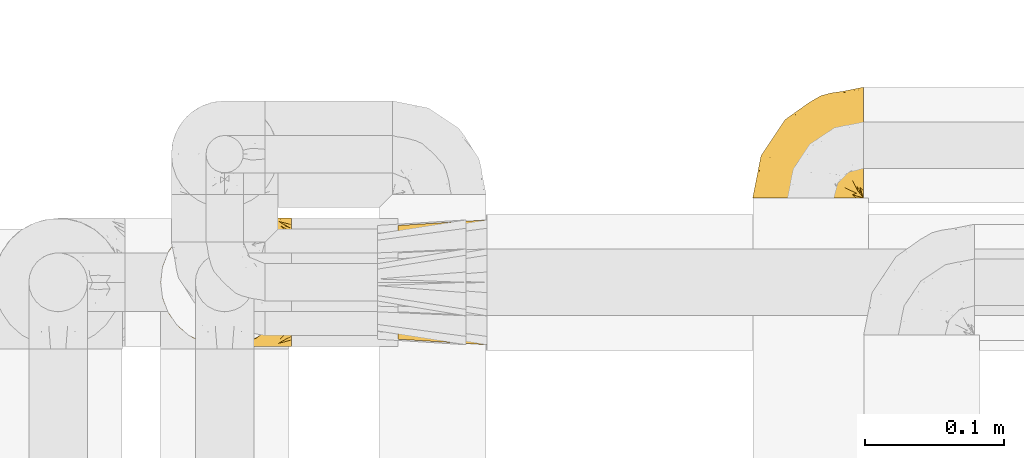
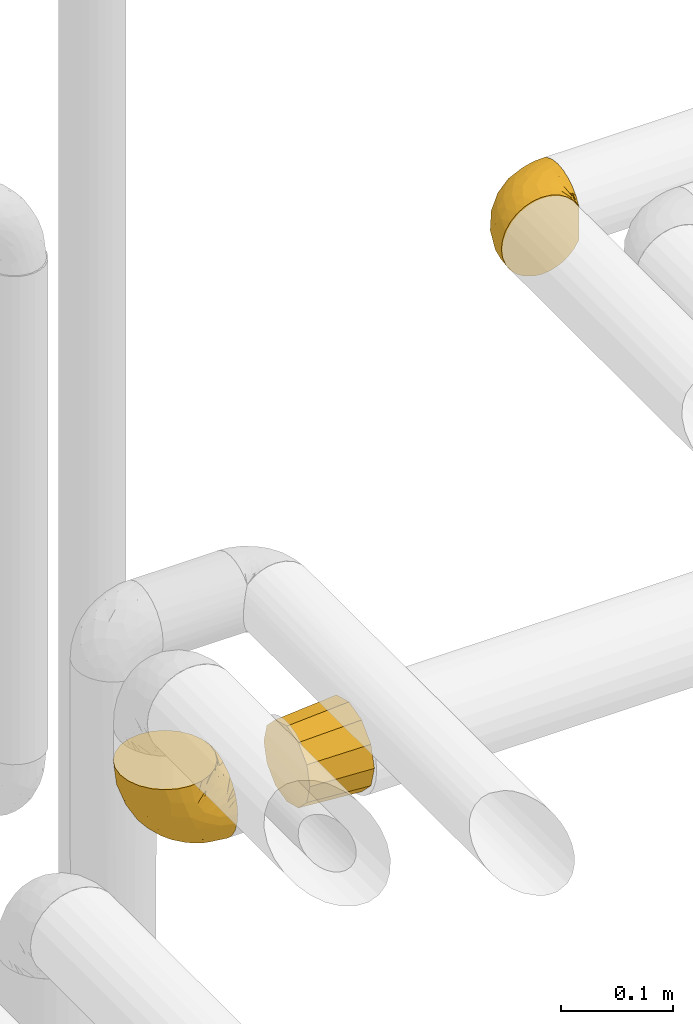
# One storey, part 430 of 827: 3 coverings.
"""IFC2X3 building model written with IfcOpenShell, lengths in millimetres."""

from ifc_helpers import new_model, entity, si_unit, converted_unit, derived_unit, direction, frame, origin, place, context, subcontext, project, spatial, faceted_brep, element, save


model = new_model("IFC2X3")

# Units and contexts
model_context = context("Model", 3, precision=0.01, world=origin(), true_north=direction((6.12303176911189e-17, 1.0)))
body_context = subcontext(model_context, "Body", "Model", "MODEL_VIEW")
ifc_project = project(units=[si_unit("LENGTHUNIT", "METRE", prefix="MILLI"), si_unit("AREAUNIT", "SQUARE_METRE"), si_unit("VOLUMEUNIT", "CUBIC_METRE"), converted_unit("PLANEANGLEUNIT", "DEGREE", entity("IfcRatioMeasure", 0.0174532925199433), si_unit("PLANEANGLEUNIT", "RADIAN"), dimensions=[0, 0, 0, 0, 0, 0, 0]), si_unit("MASSUNIT", "GRAM", prefix="KILO"), derived_unit("MASSDENSITYUNIT", [(si_unit("MASSUNIT", "GRAM", prefix="KILO"), 1), (si_unit("LENGTHUNIT", "METRE"), -3)]), derived_unit("MOMENTOFINERTIAUNIT", [(si_unit("LENGTHUNIT", "METRE"), 4)]), si_unit("TIMEUNIT", "SECOND"), si_unit("FREQUENCYUNIT", "HERTZ"), si_unit("THERMODYNAMICTEMPERATUREUNIT", "DEGREE_CELSIUS"), derived_unit("THERMALTRANSMITTANCEUNIT", [(si_unit("MASSUNIT", "GRAM", prefix="KILO"), 1), (si_unit("THERMODYNAMICTEMPERATUREUNIT", "KELVIN"), -1), (si_unit("TIMEUNIT", "SECOND"), -3)]), derived_unit("VOLUMETRICFLOWRATEUNIT", [(si_unit("LENGTHUNIT", "METRE"), 3), (si_unit("TIMEUNIT", "SECOND"), -1)]), derived_unit("MASSFLOWRATEUNIT", [(si_unit("MASSUNIT", "GRAM", prefix="KILO"), 1), (si_unit("TIMEUNIT", "SECOND"), -1)]), derived_unit("ROTATIONALFREQUENCYUNIT", [(si_unit("TIMEUNIT", "SECOND"), -1)]), si_unit("ELECTRICCURRENTUNIT", "AMPERE"), si_unit("ELECTRICVOLTAGEUNIT", "VOLT"), si_unit("POWERUNIT", "WATT"), si_unit("FORCEUNIT", "NEWTON", prefix="KILO"), si_unit("ILLUMINANCEUNIT", "LUX"), si_unit("LUMINOUSFLUXUNIT", "LUMEN"), si_unit("LUMINOUSINTENSITYUNIT", "CANDELA"), derived_unit("USERDEFINED", [(si_unit("MASSUNIT", "GRAM", prefix="KILO"), -1), (si_unit("LENGTHUNIT", "METRE"), -2), (si_unit("TIMEUNIT", "SECOND"), 3), (si_unit("LUMINOUSFLUXUNIT", "LUMEN"), 1)]), derived_unit("LINEARVELOCITYUNIT", [(si_unit("LENGTHUNIT", "METRE"), 1), (si_unit("TIMEUNIT", "SECOND"), -1)]), si_unit("PRESSUREUNIT", "PASCAL"), derived_unit("USERDEFINED", [(si_unit("LENGTHUNIT", "METRE"), -2), (si_unit("MASSUNIT", "GRAM", prefix="KILO"), 1), (si_unit("TIMEUNIT", "SECOND"), -2)]), derived_unit("LINEARFORCEUNIT", [(si_unit("MASSUNIT", "GRAM", prefix="KILO"), 1), (si_unit("LENGTHUNIT", "METRE"), 1), (si_unit("TIMEUNIT", "SECOND"), -2), (si_unit("LENGTHUNIT", "METRE"), -1)]), derived_unit("PLANARFORCEUNIT", [(si_unit("MASSUNIT", "GRAM", prefix="KILO"), 1), (si_unit("LENGTHUNIT", "METRE"), 1), (si_unit("TIMEUNIT", "SECOND"), -2), (si_unit("LENGTHUNIT", "METRE"), -2)])], contexts=[model_context])

# Site, building, storey
site_placement = place(None, origin())
site = spatial("IfcSite", under=ifc_project, at=site_placement, CompositionType="ELEMENT")
building_placement = place(site_placement, origin())
building = spatial("IfcBuilding", under=site, at=building_placement, CompositionType="ELEMENT")
storey_placement = place(building_placement, frame((0.0, 0.0, 28200.0)))
storey = spatial("IfcBuildingStorey", under=building, at=storey_placement, Name="08", CompositionType="ELEMENT", Elevation=28200.0)

# Coverings
covering_1_placement = place(storey_placement, frame((54141.99, 17452.2, 2519.7)))
element("IfcCovering", 1, at=covering_1_placement, inside=storey, Name=":ADSK_", ObjectType=":ADSK_", PredefinedType="INSULATION", context=body_context, shape_type="Brep", body=[
    faceted_brep([(95.8, 11.68, 18.98), (95.8, 19.0, 11.67), (95.8, 27.76, 6.17), (95.8, 37.52, 2.75), (95.8, 47.8, 1.6), (95.8, 58.08, 2.75), (95.8, 67.85, 6.17), (95.8, 76.61, 11.68), (95.8, 83.92, 19.0), (95.8, 89.42, 27.76), (95.8, 92.84, 37.52), (95.8, 94.0, 47.8), (95.8, 93.53, 51.94), (95.8, 93.18, 55.01), (95.8, 92.84, 58.08), (95.8, 91.13, 62.96), (95.8, 89.42, 67.85), (95.8, 86.66, 72.23), (95.8, 83.91, 76.61), (95.8, 80.25, 80.26), (95.8, 76.59, 83.92), (95.8, 67.83, 89.42), (95.8, 62.95, 91.13), (95.8, 58.07, 92.84), (95.8, 47.8, 94.0), (95.8, 37.51, 92.84), (95.8, 32.63, 91.13), (95.8, 27.74, 89.42), (95.8, 18.98, 83.91), (95.8, 15.33, 80.25), (95.8, 11.67, 76.59), (95.8, 8.92, 72.21), (95.8, 6.17, 67.83), (95.8, 4.46, 62.95), (95.8, 2.75, 58.07), (95.8, 2.41, 55.0), (95.8, 2.06, 51.94), (95.8, 1.6, 47.8), (95.8, 2.75, 37.51), (95.8, 6.17, 27.74), (94.0, 47.8, 95.8), (92.42, 59.75, 95.8), (87.81, 70.9, 95.8), (84.13, 75.68, 95.8), (80.46, 80.46, 95.8), (75.68, 84.13, 95.8), (70.9, 87.81, 95.8), (65.32, 90.11, 95.8), (59.75, 92.42, 95.8), (56.14, 92.9, 95.8), (54.06, 93.17, 95.8), (51.97, 93.45, 95.8), (47.8, 94.0, 95.8), (35.84, 92.42, 95.8), (24.7, 87.81, 95.8), (15.13, 80.46, 95.8), (7.78, 70.9, 95.8), (3.17, 59.75, 95.8), (1.6, 47.8, 95.8), (3.17, 35.84, 95.8), (7.78, 24.7, 95.8), (15.13, 15.13, 95.8), (24.7, 7.78, 95.8), (35.84, 3.17, 95.8), (47.8, 1.6, 95.8), (51.97, 2.14, 95.8), (56.14, 2.69, 95.8), (59.75, 3.17, 95.8), (65.32, 5.48, 95.8), (70.9, 7.78, 95.8), (75.68, 11.46, 95.8), (80.46, 15.13, 95.8), (84.13, 19.91, 95.8), (87.81, 24.7, 95.8), (92.42, 35.84, 95.8), (15.84, 23.61, 60.58), (6.99, 31.99, 74.11), (14.39, 35.87, 51.59), (6.21, 47.8, 66.69), (4.26, 40.43, 76.19), (3.39, 47.8, 84.43), (31.2, 31.83, 31.2), (26.47, 23.37, 42.88), (11.44, 21.41, 79.41), (47.66, 3.07, 60.7), (61.85, 1.6, 61.85), (59.25, 1.6, 65.75), (56.65, 1.6, 69.64), (54.05, 1.6, 73.53), (51.45, 1.6, 77.43), (19.8, 13.45, 74.59), (26.22, 15.25, 54.72), (31.58, 8.07, 64.18), (38.36, 16.0, 37.94), (51.54, 17.34, 25.89), (51.6, 10.58, 34.73), (55.97, 5.34, 42.89), (62.88, 2.39, 49.83), (41.35, 8.36, 48.58), (82.24, 10.04, 22.41), (40.88, 2.59, 78.69), (29.0, 6.28, 81.64), (74.06, 34.28, 6.22), (54.53, 38.73, 12.11), (57.98, 27.25, 14.81), (43.81, 29.88, 21.61), (38.22, 38.6, 22.41), (38.33, 23.44, 30.12), (74.76, 25.25, 10.01), (76.85, 17.23, 15.36), (84.43, 47.8, 3.39), (40.43, 47.8, 19.59), (30.01, 47.8, 30.01), (78.67, 2.53, 41.19), (92.06, 1.6, 48.54), (88.32, 1.6, 49.28), (85.6, 1.6, 49.82), (82.88, 1.6, 50.37), (80.15, 1.6, 50.91), (77.43, 1.6, 51.45), (76.36, 5.71, 31.61), (50.91, 1.6, 80.15), (50.37, 1.6, 82.88), (49.82, 1.6, 85.6), (49.28, 1.6, 88.32), (48.91, 1.6, 90.19), (48.54, 1.6, 92.06), (66.69, 47.8, 6.21), (73.53, 1.6, 54.05), (69.64, 1.6, 56.65), (65.75, 1.6, 59.25), (66.13, 11.89, 24.66), (19.59, 47.8, 40.43), (24.64, 39.69, 35.17), (53.56, 47.8, 12.9), (12.9, 47.8, 53.56), (82.81, 13.84, 85.34), (81.22, 9.16, 78.44), (86.57, 15.79, 84.37), (92.75, 25.75, 89.05), (89.68, 16.09, 82.76), (72.26, 7.51, 86.31), (64.73, 3.99, 83.73), (62.45, 2.66, 77.31), (60.63, 3.16, 87.78), (56.91, 2.35, 87.91), (58.14, 2.23, 81.29), (93.7, 38.35, 93.97), (83.4, 6.18, 70.76), (75.54, 2.7, 63.67), (79.46, 2.93, 62.62), (82.28, 16.01, 90.64), (76.25, 9.08, 84.08), (90.18, 11.68, 77.45), (84.69, 9.3, 76.28), (86.94, 21.65, 91.35), (65.12, 4.65, 88.72), (71.71, 3.65, 71.28), (75.21, 3.61, 68.09), (78.6, 12.8, 91.07), (87.27, 2.43, 57.47), (87.92, 6.83, 70.34), (86.1, 3.7, 62.99), (94.52, 47.8, 94.52), (66.23, 3.37, 76.47), (91.08, 7.03, 69.96), (71.77, 7.87, 89.86), (76.21, 7.26, 78.94), (68.59, 3.41, 73.51), (89.94, 23.81, 89.62), (76.25, 86.5, 84.09), (72.26, 88.08, 86.3), (78.6, 82.79, 91.06), (49.28, 94.0, 88.32), (48.54, 94.0, 92.06), (50.37, 94.0, 82.88), (49.82, 94.0, 85.6), (93.7, 57.24, 93.97), (89.95, 71.76, 89.63), (82.88, 94.0, 50.37), (85.6, 94.0, 49.82), (92.06, 94.0, 48.54), (88.32, 94.0, 49.28), (89.68, 79.49, 82.77), (87.92, 88.75, 70.36), (62.45, 92.93, 77.31), (66.24, 92.22, 76.47), (56.65, 94.0, 69.64), (59.25, 94.0, 65.75), (60.63, 92.43, 87.78), (56.91, 93.24, 87.91), (92.76, 69.82, 89.06), (82.28, 79.57, 90.65), (82.81, 81.74, 85.35), (54.05, 94.0, 73.53), (51.45, 94.0, 77.43), (58.14, 93.36, 81.29), (90.18, 83.9, 77.46), (84.7, 86.28, 76.29), (87.25, 93.16, 57.47), (75.58, 92.88, 63.71), (75.2, 91.98, 68.11), (83.39, 89.41, 70.77), (71.7, 91.93, 71.31), (81.22, 86.42, 78.46), (90.73, 88.82, 69.52), (79.47, 92.66, 62.64), (86.94, 73.93, 91.35), (65.75, 94.0, 59.25), (86.75, 79.5, 84.6), (86.08, 91.89, 62.98), (77.43, 94.0, 51.45), (73.53, 94.0, 54.05), (69.64, 94.0, 56.65), (64.73, 91.6, 83.73), (50.91, 94.0, 80.15), (65.12, 90.94, 88.72), (61.85, 94.0, 61.85), (68.62, 92.16, 73.56), (76.22, 88.32, 78.96), (74.03, 86.13, 91.36), (80.15, 94.0, 50.91), (49.81, 93.2, 62.87), (4.26, 55.16, 76.19), (19.95, 82.02, 73.57), (30.61, 84.29, 56.07), (25.71, 76.94, 49.77), (22.43, 68.33, 44.73), (15.85, 71.98, 60.58), (60.69, 92.52, 47.64), (40.49, 92.9, 78.32), (14.39, 59.72, 51.59), (6.99, 63.6, 74.11), (29.56, 88.89, 76.04), (11.45, 74.18, 79.41), (57.98, 68.35, 14.82), (74.06, 61.33, 6.22), (54.52, 56.86, 12.12), (43.47, 68.62, 23.51), (31.2, 63.76, 31.2), (33.27, 72.19, 34.96), (64.26, 88.69, 33.86), (74.29, 92.19, 38.94), (80.41, 89.75, 30.23), (24.64, 55.9, 35.17), (73.62, 77.99, 15.85), (78.98, 85.21, 22.59), (53.69, 74.99, 21.56), (42.86, 90.23, 55.94), (41.67, 59.86, 20.67), (79.66, 70.75, 9.19), (58.41, 81.72, 25.79), (47.11, 86.53, 41.16), (38.37, 79.6, 37.95)], [[[0, 1, 2, 3, 4, 5, 6, 7, 8, 9, 10, 11, 12, 13, 14, 15, 16, 17, 18, 19, 20, 21, 22, 23, 24, 25, 26, 27, 28, 29, 30, 31, 32, 33, 34, 35, 36, 37, 38, 39]], [[40, 41, 42, 43, 44, 45, 46, 47, 48, 49, 50, 51, 52, 53, 54, 55, 56, 57, 58, 59, 60, 61, 62, 63, 64, 65, 66, 67, 68, 69, 70, 71, 72, 73, 74]], [[75, 76, 77]], [[78, 79, 80]], [[77, 81, 82]], [[76, 75, 83]], [[84, 85, 86, 87, 88, 89]], [[90, 91, 92]], [[76, 60, 59]], [[93, 94, 95]], [[90, 62, 61]], [[83, 61, 60]], [[96, 97, 84]], [[98, 93, 95]], [[0, 39, 99]], [[100, 84, 89]], [[62, 101, 63]], [[2, 102, 3]], [[92, 84, 100]], [[103, 102, 104]], [[103, 105, 106]], [[93, 107, 94]], [[1, 108, 2]], [[92, 101, 90]], [[108, 1, 109]], [[102, 110, 3]], [[93, 82, 107]], [[102, 108, 104]], [[111, 106, 112]], [[109, 0, 99]], [[113, 37, 114, 115, 116, 117, 118, 119]], [[120, 38, 113]], [[100, 89, 121, 122, 123, 124, 125, 126, 64]], [[127, 102, 103]], [[97, 119, 128, 129, 130, 85]], [[99, 120, 131]], [[132, 133, 77]], [[59, 80, 79]], [[1, 0, 109]], [[98, 84, 92]], [[94, 109, 131]], [[120, 39, 38]], [[93, 91, 82]], [[104, 94, 105]], [[97, 113, 119]], [[95, 120, 96]], [[83, 90, 61]], [[91, 93, 98]], [[64, 63, 100]], [[100, 63, 101]], [[77, 76, 79]], [[133, 106, 81]], [[84, 97, 85]], [[113, 96, 120]], [[113, 97, 96]], [[37, 113, 38]], [[110, 102, 127]], [[110, 4, 3]], [[103, 111, 134, 127]], [[90, 75, 91]], [[82, 81, 107]], [[91, 75, 82]], [[77, 82, 75]], [[76, 83, 60]], [[90, 83, 75]], [[105, 107, 81]], [[94, 131, 95]], [[105, 94, 107]], [[109, 94, 104]], [[120, 95, 131]], [[98, 95, 96]], [[84, 98, 96]], [[98, 92, 91]], [[106, 105, 81]], [[103, 104, 105]], [[112, 106, 133]], [[103, 106, 111]], [[112, 133, 132]], [[81, 77, 133]], [[77, 78, 135, 132]], [[120, 99, 39]], [[109, 99, 131]], [[59, 58, 80]], [[59, 79, 76]], [[90, 101, 62]], [[100, 101, 92]], [[2, 108, 102]], [[109, 104, 108]], [[78, 77, 79]], [[136, 137, 138]], [[27, 139, 140]], [[141, 142, 143]], [[144, 145, 121]], [[146, 89, 88]], [[147, 139, 25]], [[148, 149, 150]], [[136, 151, 152]], [[147, 40, 74]], [[24, 147, 25]], [[153, 140, 154]], [[33, 116, 34]], [[73, 151, 155]], [[114, 37, 36, 35, 34, 116, 115]], [[146, 156, 144]], [[157, 85, 130]], [[158, 149, 148]], [[151, 159, 152]], [[117, 33, 160]], [[29, 153, 161]], [[155, 74, 73]], [[162, 128, 119]], [[66, 65, 64, 126, 125, 124, 123, 122, 67]], [[163, 147, 24]], [[27, 140, 28]], [[149, 129, 150]], [[139, 27, 26, 25]], [[68, 144, 69]], [[129, 128, 150]], [[164, 87, 86]], [[130, 129, 149]], [[122, 145, 67]], [[153, 154, 148]], [[162, 119, 160]], [[165, 30, 161]], [[150, 161, 148]], [[128, 162, 150]], [[30, 165, 31]], [[145, 144, 68]], [[89, 146, 144]], [[87, 164, 143]], [[166, 156, 142]], [[88, 87, 143]], [[162, 161, 150]], [[161, 30, 29]], [[161, 153, 148]], [[28, 140, 153]], [[29, 28, 153]], [[140, 137, 154]], [[158, 148, 154]], [[157, 130, 158]], [[154, 137, 158]], [[158, 137, 157]], [[167, 137, 136]], [[168, 85, 157]], [[152, 168, 167]], [[167, 168, 157]], [[164, 152, 141]], [[151, 73, 72]], [[159, 72, 71]], [[88, 142, 146]], [[144, 156, 69]], [[146, 142, 156]], [[70, 166, 71]], [[142, 141, 166]], [[70, 69, 156]], [[141, 159, 71]], [[167, 136, 152]], [[138, 137, 140]], [[155, 136, 169]], [[136, 155, 151]], [[74, 155, 169]], [[152, 159, 141]], [[151, 72, 159]], [[168, 152, 164]], [[137, 167, 157]], [[164, 86, 168]], [[85, 168, 86]], [[116, 33, 117]], [[130, 149, 158]], [[67, 145, 68]], [[121, 89, 144]], [[145, 122, 121]], [[40, 147, 163]], [[169, 147, 74]], [[160, 33, 32]], [[162, 160, 32]], [[160, 119, 118, 117]], [[139, 147, 169]], [[139, 169, 138]], [[162, 32, 31]], [[141, 143, 164]], [[88, 143, 142]], [[71, 166, 141]], [[156, 166, 70]], [[139, 138, 140]], [[169, 136, 138]], [[161, 162, 165]], [[162, 31, 165]], [[170, 171, 172]], [[173, 174, 52, 51, 50, 49, 48, 175, 176]], [[177, 178, 41]], [[179, 15, 180]], [[12, 11, 181, 182, 180, 14, 13]], [[183, 21, 20]], [[19, 18, 184]], [[185, 186, 187]], [[186, 188, 187]], [[43, 172, 44]], [[189, 190, 47]], [[23, 22, 21, 191]], [[170, 192, 193]], [[40, 163, 177]], [[194, 195, 196]], [[24, 23, 177]], [[197, 198, 183]], [[199, 15, 179]], [[47, 46, 189]], [[200, 201, 202]], [[201, 203, 204]], [[205, 206, 184]], [[207, 41, 178]], [[16, 15, 199]], [[14, 180, 15]], [[202, 201, 198]], [[208, 201, 200]], [[163, 24, 177]], [[48, 47, 190]], [[196, 195, 189]], [[197, 184, 202]], [[204, 193, 209]], [[210, 211, 212]], [[206, 212, 213]], [[205, 17, 210]], [[184, 206, 202]], [[210, 212, 206]], [[185, 194, 214]], [[189, 215, 190]], [[216, 45, 214]], [[186, 171, 170]], [[189, 216, 196]], [[197, 20, 19]], [[194, 185, 187]], [[197, 183, 20]], [[184, 197, 19]], [[197, 202, 198]], [[206, 200, 202]], [[204, 183, 198]], [[201, 208, 203]], [[203, 208, 217]], [[204, 198, 201]], [[217, 188, 218]], [[193, 219, 170]], [[171, 186, 185]], [[170, 218, 186]], [[170, 219, 218]], [[42, 207, 192]], [[171, 220, 172]], [[216, 189, 46]], [[214, 194, 196]], [[44, 220, 45]], [[214, 196, 216]], [[216, 46, 45]], [[214, 45, 220]], [[192, 43, 42]], [[204, 203, 219]], [[207, 193, 192]], [[209, 193, 178]], [[41, 207, 42]], [[193, 207, 178]], [[43, 192, 172]], [[170, 172, 192]], [[204, 219, 193]], [[219, 203, 218]], [[217, 218, 203]], [[188, 186, 218]], [[206, 213, 200]], [[208, 200, 213]], [[199, 210, 16]], [[215, 189, 195]], [[215, 175, 190]], [[175, 48, 190]], [[199, 179, 221, 211]], [[210, 199, 211]], [[23, 191, 177]], [[40, 177, 41]], [[178, 177, 191]], [[21, 183, 191]], [[209, 191, 183]], [[205, 18, 17]], [[17, 16, 210]], [[171, 185, 214]], [[172, 220, 44]], [[214, 220, 171]], [[191, 209, 178]], [[204, 209, 183]], [[206, 205, 210]], [[18, 205, 184]], [[222, 195, 194, 187, 188, 217]], [[57, 223, 80]], [[224, 225, 226]], [[226, 227, 228]], [[229, 217, 208, 213, 212, 211]], [[230, 52, 174, 173, 176, 175, 215, 195]], [[231, 232, 228]], [[231, 78, 223]], [[223, 57, 232]], [[224, 233, 225]], [[233, 54, 53]], [[234, 232, 56]], [[56, 55, 234]], [[234, 224, 228]], [[235, 236, 237]], [[224, 55, 54]], [[238, 239, 240]], [[52, 230, 53]], [[241, 242, 243]], [[231, 227, 244]], [[11, 10, 242]], [[236, 6, 5]], [[7, 245, 8]], [[8, 246, 9]], [[238, 247, 235]], [[222, 229, 248]], [[242, 211, 221, 179, 180, 182, 181, 11]], [[233, 53, 230]], [[111, 112, 249]], [[250, 6, 236]], [[246, 251, 241]], [[6, 250, 7]], [[127, 236, 110]], [[248, 229, 252]], [[246, 8, 245]], [[235, 245, 250]], [[236, 5, 110]], [[235, 249, 238]], [[237, 236, 127]], [[243, 9, 246]], [[252, 229, 241]], [[56, 232, 57]], [[222, 230, 195]], [[225, 248, 252]], [[248, 233, 230]], [[54, 233, 224]], [[231, 228, 227]], [[244, 132, 231]], [[248, 225, 233]], [[226, 225, 253]], [[235, 250, 236]], [[245, 7, 250]], [[251, 246, 245]], [[243, 246, 241]], [[247, 245, 235]], [[252, 251, 253]], [[229, 222, 217]], [[230, 222, 248]], [[5, 4, 110]], [[237, 127, 134, 111]], [[238, 249, 239]], [[224, 234, 55]], [[232, 234, 228]], [[242, 241, 229]], [[10, 9, 243]], [[211, 242, 229]], [[10, 243, 242]], [[80, 223, 78]], [[80, 58, 57]], [[231, 223, 232]], [[227, 240, 239]], [[224, 226, 228]], [[240, 226, 253]], [[227, 239, 244]], [[226, 240, 227]], [[251, 247, 253]], [[240, 253, 247]], [[249, 235, 237]], [[237, 111, 249]], [[244, 239, 249]], [[112, 244, 249]], [[135, 78, 231, 132]], [[112, 132, 244]], [[247, 238, 240]], [[245, 247, 251]], [[251, 252, 241]], [[225, 252, 253]]]),
])
covering_2_placement = place(storey_placement, frame((54314.79, 17453.4, 2520.9)))
element("IfcCovering", 2, at=covering_2_placement, inside=storey, Name=":ADSK_", ObjectType=":ADSK_", PredefinedType="INSULATION", context=body_context, shape_type="Brep", body=[
    faceted_brep([(0.0, 74.6, 74.6), (0.0, 82.1, 67.1), (0.0, 84.85, 56.85), (0.0, 87.6, 46.6), (0.0, 84.85, 36.35), (0.0, 82.1, 26.1), (0.0, 74.6, 18.59), (0.0, 67.1, 11.09), (0.0, 56.85, 8.34), (0.0, 46.6, 5.6), (0.0, 36.35, 8.34), (0.0, 26.1, 11.09), (0.0, 18.59, 18.59), (0.0, 11.09, 26.1), (0.0, 8.34, 36.35), (0.0, 5.6, 46.6), (0.0, 8.34, 56.85), (0.0, 11.09, 67.1), (0.0, 18.59, 74.6), (0.0, 26.1, 82.1), (0.0, 36.35, 84.85), (0.0, 46.6, 87.6), (0.0, 56.85, 84.85), (0.0, 67.1, 82.1), (64.0, 33.21, 88.01), (64.0, 24.1, 85.57), (64.0, 15.86, 77.33), (64.0, 7.62, 69.1), (64.0, 5.18, 59.99), (64.0, 1.6, 46.6), (64.0, 5.18, 33.21), (64.0, 7.62, 24.1), (64.0, 15.86, 15.86), (64.0, 24.1, 7.62), (64.0, 33.21, 5.18), (64.0, 46.6, 1.6), (64.0, 59.99, 5.18), (64.0, 69.1, 7.62), (64.0, 77.33, 15.86), (64.0, 85.57, 24.1), (64.0, 88.01, 33.21), (64.0, 91.6, 46.6), (64.0, 88.01, 59.99), (64.0, 85.57, 69.1), (64.0, 77.33, 77.33), (64.0, 69.1, 85.57), (64.0, 59.99, 88.01), (64.0, 46.6, 91.6)], [[[0, 1, 2, 3, 4, 5, 6, 7, 8, 9, 10, 11, 12, 13, 14, 15, 16, 17, 18, 19, 20, 21, 22, 23]], [[24, 25, 26, 27, 28, 29, 30, 31, 32, 33, 34, 35, 36, 37, 38, 39, 40, 41, 42, 43, 44, 45, 46, 47]], [[7, 37, 36, 35, 9, 8]], [[39, 38, 37, 7, 6, 5]], [[4, 3, 41, 40, 39, 5]], [[13, 31, 30, 29, 15, 14]], [[33, 32, 31, 13, 12, 11]], [[10, 9, 35, 34, 33, 11]], [[19, 25, 24, 47, 21, 20]], [[27, 26, 25, 19, 18, 17]], [[16, 15, 29, 28, 27, 17]], [[1, 43, 42, 41, 3, 2]], [[45, 44, 43, 1, 0, 23]], [[22, 21, 47, 46, 45, 23]]]),
])
covering_3_placement = place(storey_placement, frame((54568.74, 17559.22, 2956.64)))
element("IfcCovering", 3, at=covering_3_placement, inside=storey, Name=":ADSK_", ObjectType=":ADSK_", PredefinedType="INSULATION", context=body_context, shape_type="Brep", body=[
    faceted_brep([(25.28, 1.6, 81.15), (17.35, 1.6, 76.16), (10.72, 1.6, 69.53), (5.74, 1.6, 61.6), (2.64, 1.6, 52.75), (1.6, 1.6, 43.45), (2.65, 1.6, 34.13), (5.74, 1.6, 25.28), (10.73, 1.6, 17.35), (17.36, 1.6, 10.72), (25.29, 1.6, 5.74), (34.14, 1.6, 2.64), (43.45, 1.6, 1.6), (52.82, 1.6, 2.66), (61.71, 1.6, 5.79), (69.67, 1.6, 10.83), (76.31, 1.6, 17.53), (81.27, 1.6, 25.53), (81.27, 1.6, 26.45), (81.27, 1.6, 27.37), (81.27, 1.6, 28.17), (81.27, 1.6, 29.49), (81.27, 1.6, 30.81), (81.27, 1.6, 32.13), (81.27, 1.6, 33.45), (81.27, 1.6, 34.78), (81.27, 1.6, 36.1), (81.27, 1.6, 37.42), (81.27, 1.6, 38.74), (81.27, 1.6, 40.06), (81.27, 1.6, 41.38), (81.27, 1.6, 42.7), (81.27, 1.6, 44.02), (81.27, 1.6, 45.34), (81.27, 1.6, 46.66), (81.27, 1.6, 47.58), (81.27, 1.6, 48.5), (81.27, 1.6, 49.41), (81.27, 1.6, 50.33), (81.27, 1.6, 51.25), (81.27, 1.6, 52.17), (81.27, 1.6, 53.09), (81.27, 1.6, 54.01), (81.27, 1.6, 54.93), (81.27, 1.6, 55.85), (81.27, 1.6, 56.76), (81.27, 1.6, 57.68), (81.27, 1.6, 58.6), (81.27, 1.6, 59.52), (81.27, 1.6, 60.44), (81.27, 1.6, 61.36), (76.3, 1.6, 69.37), (69.66, 1.6, 76.07), (61.69, 1.6, 81.11), (52.8, 1.6, 84.24), (43.45, 1.6, 85.3), (34.13, 1.6, 84.24), (81.45, 6.74, 17.52), (81.45, 13.37, 10.83), (81.45, 21.34, 5.79), (81.45, 30.23, 2.66), (81.45, 39.6, 1.6), (81.45, 50.43, 3.02), (81.45, 60.52, 7.2), (81.45, 69.19, 13.85), (81.45, 75.84, 22.52), (81.45, 80.02, 32.61), (81.45, 81.45, 43.45), (81.45, 80.02, 54.28), (81.45, 75.84, 64.37), (81.45, 69.19, 73.04), (81.45, 60.52, 79.69), (81.45, 50.43, 83.87), (81.45, 39.6, 85.3), (81.45, 30.23, 84.23), (81.45, 21.34, 81.1), (81.45, 13.37, 76.06), (81.45, 6.74, 69.37), (81.45, 1.77, 61.36), (81.45, 1.77, 60.44), (81.45, 1.77, 59.12), (81.45, 1.77, 58.0), (81.45, 1.77, 56.88), (81.45, 1.77, 55.76), (81.45, 1.77, 54.64), (81.45, 1.77, 53.52), (81.45, 1.77, 52.4), (81.45, 1.77, 51.28), (81.45, 1.77, 50.16), (81.45, 1.77, 49.04), (81.45, 1.77, 47.92), (81.45, 1.77, 46.8), (81.45, 1.77, 45.68), (81.45, 1.77, 44.56), (81.45, 1.77, 43.45), (81.45, 1.77, 42.12), (81.45, 1.77, 40.8), (81.45, 1.77, 39.48), (81.45, 1.77, 38.16), (81.45, 1.77, 36.84), (81.45, 1.77, 35.52), (81.45, 1.77, 34.2), (81.45, 1.77, 32.88), (81.45, 1.77, 31.96), (81.45, 1.77, 31.05), (81.45, 1.77, 30.13), (81.45, 1.77, 29.21), (81.45, 1.77, 28.29), (81.45, 1.77, 27.37), (81.45, 1.77, 26.45), (81.45, 1.77, 25.53), (81.33, 1.73, 54.08), (81.32, 1.72, 55.16), (81.33, 1.73, 36.18), (81.32, 1.72, 35.13), (81.33, 1.73, 44.01), (81.32, 1.73, 45.08), (81.32, 1.72, 61.36), (81.32, 1.72, 59.98), (81.32, 1.72, 46.18), (81.32, 1.72, 26.74), (81.32, 1.72, 47.36), (81.32, 1.73, 29.67), (81.34, 1.74, 28.72), (81.32, 1.72, 39.77), (81.31, 1.71, 52.96), (81.33, 1.73, 51.84), (81.31, 1.71, 40.8), (81.32, 1.72, 41.87), (81.33, 1.73, 42.94), (81.32, 1.72, 27.77), (81.33, 1.73, 48.4), (81.32, 1.72, 37.21), (81.33, 1.73, 33.54), (81.32, 1.72, 32.49), (81.32, 1.72, 30.69), (81.32, 1.72, 50.69), (81.31, 1.71, 49.6), (81.32, 1.72, 56.32), (81.33, 1.73, 57.44), (81.31, 1.71, 58.88), (81.32, 1.72, 25.53), (81.3, 1.68, 61.36), (81.29, 1.64, 61.36), (81.29, 1.64, 25.53), (81.3, 1.68, 25.53), (81.4, 1.75, 61.36), (81.36, 1.74, 25.53), (81.36, 1.74, 61.36), (81.4, 1.75, 25.53), (81.3, 1.7, 31.59), (81.33, 1.73, 38.71), (74.06, 24.54, 3.97), (45.99, 11.1, 1.6), (58.35, 8.47, 3.97), (67.76, 9.11, 8.09), (66.18, 4.86, 8.09), (76.46, 5.0, 16.43), (77.33, 6.81, 15.73), (71.95, 37.05, 1.6), (72.25, 9.03, 10.79), (78.91, 9.47, 13.99), (76.42, 16.39, 8.08), (73.52, 3.95, 14.0), (76.9, 9.9, 12.83), (65.25, 22.7, 3.18), (62.45, 34.5, 1.6), (74.31, 37.68, 1.6), (59.38, 15.82, 3.28), (48.54, 20.6, 1.6), (67.72, 14.37, 6.28), (55.49, 27.55, 1.6), (79.73, 5.2, 19.06), (73.23, 14.88, 8.08), (45.36, 8.73, 1.6), (15.81, 44.27, 32.11), (6.4, 20.94, 29.62), (7.67, 32.15, 43.45), (68.46, 46.13, 2.45), (59.33, 42.67, 2.5), (48.7, 55.18, 9.73), (53.94, 67.27, 17.97), (65.02, 62.91, 10.24), (60.77, 51.5, 4.78), (72.07, 54.79, 4.78), (26.25, 25.78, 8.01), (22.29, 13.05, 8.01), (16.0, 18.46, 13.85), (46.93, 32.4, 2.42), (14.19, 31.07, 21.17), (58.46, 77.32, 35.73), (61.51, 75.62, 27.43), (4.64, 16.9, 43.45), (68.93, 71.69, 17.97), (29.62, 61.4, 35.71), (24.85, 54.47, 29.47), (38.55, 27.66, 3.41), (31.27, 14.53, 3.94), (9.35, 15.56, 21.17), (37.15, 42.26, 7.92), (47.07, 41.51, 4.25), (26.49, 36.93, 11.75), (23.01, 42.72, 18.31), (19.4, 44.68, 24.94), (48.06, 71.2, 28.78), (42.46, 70.48, 35.82), (50.89, 75.37, 43.45), (35.78, 63.65, 28.38), (24.98, 58.06, 43.45), (16.33, 45.11, 43.45), (66.14, 78.4, 43.45), (30.96, 54.95, 21.21), (41.83, 59.31, 16.48), (33.28, 49.01, 13.85), (37.94, 66.71, 43.45), (67.39, 53.75, 82.11), (58.47, 77.27, 51.41), (32.5, 61.6, 57.45), (15.79, 44.24, 54.78), (15.99, 18.46, 73.03), (9.34, 15.55, 65.7), (56.91, 60.14, 76.65), (63.5, 70.5, 68.92), (44.08, 63.0, 68.01), (26.24, 25.78, 78.88), (22.27, 13.05, 78.88), (31.26, 14.53, 82.94), (23.95, 48.5, 64.44), (63.79, 44.23, 84.49), (62.45, 34.5, 85.3), (71.95, 37.05, 85.3), (45.36, 8.73, 85.3), (67.83, 77.68, 57.84), (70.28, 64.08, 76.65), (42.11, 70.25, 51.19), (6.39, 20.93, 57.26), (43.54, 49.9, 78.14), (58.03, 49.6, 82.35), (14.18, 31.06, 65.7), (56.34, 39.62, 84.61), (48.09, 34.42, 84.36), (48.54, 20.6, 85.3), (55.49, 27.55, 85.3), (21.78, 33.36, 73.03), (38.54, 27.68, 83.48), (45.99, 11.1, 85.3), (72.79, 46.67, 84.54), (33.26, 49.0, 73.03), (35.53, 38.94, 79.54), (53.66, 73.05, 59.46), (43.03, 56.63, 73.5), (49.68, 43.85, 82.57), (74.06, 24.54, 82.92), (59.37, 15.82, 83.62), (58.34, 8.47, 82.92), (67.75, 9.12, 78.81), (78.91, 9.47, 72.9), (76.9, 9.91, 74.06), (78.08, 16.85, 78.81), (73.23, 14.88, 78.81), (79.73, 5.2, 67.83), (77.34, 6.81, 71.15), (73.51, 3.96, 72.91), (76.45, 5.0, 70.47), (66.41, 5.86, 78.81), (67.7, 14.38, 80.62), (72.24, 9.04, 76.11), (65.25, 22.7, 83.71)], [[[0, 1, 2, 3, 4, 5, 6, 7, 8, 9, 10, 11, 12, 13, 14, 15, 16, 17, 18, 19, 20, 21, 22, 23, 24, 25, 26, 27, 28, 29, 30, 31, 32, 33, 34, 35, 36, 37, 38, 39, 40, 41, 42, 43, 44, 45, 46, 47, 48, 49, 50, 51, 52, 53, 54, 55, 56]], [[57, 58, 59, 60, 61, 62, 63, 64, 65, 66, 67, 68, 69, 70, 71, 72, 73, 74, 75, 76, 77, 78, 79, 80, 81, 82, 83, 84, 85, 86, 87, 88, 89, 90, 91, 92, 93, 94, 95, 96, 97, 98, 99, 100, 101, 102, 103, 104, 105, 106, 107, 108, 109, 110]], [[111, 84, 112]], [[113, 26, 114]], [[114, 101, 100]], [[115, 93, 116]], [[79, 117, 118]], [[33, 116, 119]], [[117, 49, 118]], [[19, 18, 120]], [[119, 121, 34]], [[122, 21, 123]], [[97, 96, 124]], [[86, 125, 126]], [[116, 92, 119]], [[127, 96, 128]], [[32, 129, 115]], [[19, 120, 130]], [[121, 90, 131]], [[94, 115, 129]], [[115, 116, 32]], [[118, 49, 48]], [[113, 99, 132]], [[133, 114, 25]], [[24, 134, 133]], [[135, 22, 122]], [[136, 137, 88]], [[84, 83, 112]], [[138, 82, 139]], [[130, 20, 19]], [[118, 48, 140]], [[81, 140, 139]], [[123, 21, 20]], [[141, 120, 18]], [[139, 82, 81]], [[130, 107, 123]], [[49, 117, 142, 143, 50]], [[18, 17, 144, 145, 141]], [[79, 78, 146]], [[109, 141, 147]], [[79, 148, 117]], [[109, 149, 110]], [[102, 133, 134]], [[105, 135, 122]], [[118, 80, 79]], [[80, 118, 140]], [[120, 109, 108]], [[47, 46, 140, 48]], [[81, 80, 140]], [[44, 112, 138]], [[93, 115, 94]], [[46, 139, 140]], [[46, 45, 139]], [[139, 45, 138]], [[138, 112, 83]], [[85, 84, 111]], [[112, 43, 111]], [[83, 82, 138]], [[106, 122, 123]], [[105, 122, 106]], [[21, 122, 22]], [[124, 29, 28]], [[33, 32, 116]], [[128, 129, 31]], [[32, 31, 129]], [[34, 33, 119]], [[116, 93, 92]], [[129, 95, 94]], [[95, 129, 128]], [[41, 40, 125, 42]], [[119, 91, 121]], [[36, 35, 131, 37]], [[137, 131, 89]], [[121, 131, 35]], [[90, 121, 91]], [[119, 92, 91]], [[136, 126, 39]], [[125, 86, 85]], [[42, 125, 111]], [[85, 111, 125]], [[150, 23, 22]], [[130, 108, 107]], [[130, 123, 20]], [[107, 106, 123]], [[137, 37, 131]], [[136, 38, 137]], [[89, 88, 137]], [[131, 90, 89]], [[124, 151, 97]], [[40, 39, 126]], [[87, 126, 136]], [[86, 126, 87]], [[136, 88, 87]], [[40, 126, 125]], [[39, 38, 136]], [[95, 128, 96]], [[30, 128, 31]], [[29, 124, 127]], [[127, 128, 30]], [[151, 124, 28]], [[127, 30, 29]], [[127, 124, 96]], [[151, 98, 97]], [[45, 44, 138]], [[26, 113, 132]], [[113, 100, 99]], [[132, 151, 27]], [[27, 26, 132]], [[26, 25, 114]], [[100, 113, 114]], [[101, 133, 102]], [[133, 101, 114]], [[28, 27, 151]], [[132, 99, 98]], [[23, 134, 24]], [[25, 24, 133]], [[134, 23, 150]], [[135, 104, 150]], [[150, 104, 103]], [[103, 102, 134]], [[130, 120, 108]], [[109, 120, 141]], [[42, 111, 43]], [[112, 44, 43]], [[104, 135, 105]], [[134, 150, 103]], [[135, 150, 22]], [[35, 34, 121]], [[137, 38, 37]], [[98, 151, 132]], [[59, 152, 60]], [[13, 153, 154]], [[155, 156, 154]], [[157, 158, 141]], [[159, 60, 152]], [[160, 157, 155]], [[161, 162, 58]], [[58, 162, 59]], [[144, 16, 163]], [[58, 57, 161]], [[162, 161, 164]], [[157, 163, 155]], [[163, 16, 15]], [[57, 149, 161]], [[152, 165, 166]], [[157, 144, 163]], [[60, 159, 167, 61]], [[156, 14, 154]], [[163, 156, 155]], [[155, 154, 168]], [[168, 154, 169]], [[155, 170, 160]], [[57, 110, 149]], [[144, 17, 16]], [[156, 15, 14]], [[171, 165, 168]], [[158, 164, 172]], [[14, 13, 154]], [[157, 141, 145, 144]], [[173, 164, 158]], [[173, 160, 170]], [[171, 166, 165]], [[168, 165, 170]], [[168, 169, 171]], [[152, 173, 165]], [[170, 155, 168]], [[165, 173, 170]], [[160, 173, 158]], [[172, 149, 147]], [[147, 141, 158]], [[158, 157, 160]], [[152, 166, 159]], [[173, 152, 162]], [[59, 162, 152]], [[13, 12, 174, 153]], [[153, 169, 154]], [[15, 156, 163]], [[162, 164, 173]], [[172, 164, 161]], [[149, 172, 161]], [[158, 172, 147]], [[175, 176, 177]], [[178, 166, 179]], [[180, 181, 182]], [[183, 184, 178]], [[185, 186, 187]], [[171, 188, 179]], [[174, 12, 11]], [[189, 176, 175]], [[190, 66, 191]], [[176, 6, 192]], [[193, 65, 64]], [[63, 184, 182]], [[63, 182, 64]], [[65, 193, 191]], [[184, 63, 62]], [[175, 194, 195]], [[196, 169, 197]], [[174, 11, 197]], [[8, 7, 198]], [[187, 9, 8]], [[197, 169, 153, 174]], [[197, 11, 10]], [[186, 197, 10]], [[199, 180, 200]], [[197, 185, 196]], [[201, 189, 202]], [[201, 187, 189]], [[195, 203, 175]], [[191, 204, 190]], [[176, 7, 6]], [[177, 176, 192]], [[189, 198, 176]], [[65, 191, 66]], [[198, 187, 8]], [[205, 206, 190]], [[9, 186, 10]], [[181, 207, 204]], [[208, 175, 177, 209]], [[66, 190, 210]], [[211, 212, 213]], [[190, 204, 205]], [[180, 182, 183]], [[193, 182, 181]], [[62, 61, 167]], [[196, 185, 199]], [[196, 200, 188]], [[6, 5, 192]], [[176, 198, 7]], [[187, 198, 189]], [[187, 186, 9]], [[197, 186, 185]], [[200, 180, 183]], [[180, 213, 212]], [[179, 183, 178]], [[185, 201, 199]], [[210, 190, 206]], [[210, 67, 66]], [[205, 204, 207]], [[194, 205, 207]], [[194, 214, 205]], [[195, 194, 207]], [[208, 194, 175]], [[207, 211, 195]], [[202, 203, 211]], [[212, 207, 181]], [[202, 211, 213]], [[201, 202, 213]], [[189, 175, 203]], [[199, 201, 213]], [[187, 201, 185]], [[180, 199, 213]], [[196, 199, 200]], [[211, 203, 195]], [[189, 203, 202]], [[207, 212, 211]], [[180, 212, 181]], [[214, 194, 208]], [[214, 206, 205]], [[196, 188, 169]], [[181, 204, 191]], [[182, 193, 64]], [[191, 193, 181]], [[178, 62, 167]], [[182, 184, 183]], [[62, 178, 184]], [[178, 167, 159, 166]], [[171, 179, 166]], [[200, 183, 179]], [[179, 188, 200]], [[169, 188, 171]], [[71, 215, 72]], [[206, 216, 210]], [[217, 208, 218]], [[216, 68, 210]], [[219, 220, 2]], [[221, 222, 223]], [[224, 225, 226]], [[227, 223, 217]], [[228, 229, 230]], [[56, 231, 226]], [[232, 222, 69]], [[56, 55, 231]], [[70, 233, 71]], [[71, 233, 215]], [[0, 56, 226]], [[208, 217, 234]], [[218, 177, 235]], [[221, 236, 237]], [[238, 220, 219]], [[1, 219, 2]], [[68, 216, 232]], [[235, 3, 220]], [[235, 192, 4]], [[1, 0, 225]], [[228, 239, 229]], [[240, 241, 242]], [[243, 238, 219]], [[224, 226, 244]], [[226, 241, 244]], [[3, 235, 4]], [[69, 222, 70]], [[225, 219, 1]], [[218, 235, 238]], [[243, 219, 224]], [[218, 227, 217]], [[3, 2, 220]], [[218, 208, 209, 177]], [[226, 231, 245, 241]], [[215, 228, 246]], [[247, 248, 236]], [[248, 224, 244]], [[223, 222, 249]], [[233, 222, 221]], [[242, 239, 240]], [[248, 247, 243]], [[217, 223, 249]], [[250, 247, 236]], [[216, 234, 249]], [[218, 238, 227]], [[192, 235, 177]], [[192, 5, 4]], [[72, 246, 73]], [[235, 220, 238]], [[226, 225, 0]], [[219, 225, 224]], [[240, 248, 244]], [[239, 242, 229]], [[236, 248, 251]], [[68, 67, 210]], [[234, 216, 206]], [[216, 249, 232]], [[234, 206, 214, 208]], [[249, 234, 217]], [[222, 232, 249]], [[69, 68, 232]], [[246, 228, 230]], [[237, 228, 215]], [[243, 227, 238]], [[223, 227, 247]], [[73, 246, 230]], [[215, 246, 72]], [[248, 243, 224]], [[227, 243, 247]], [[237, 236, 251]], [[250, 221, 223]], [[222, 233, 70]], [[215, 233, 221]], [[221, 237, 215]], [[239, 237, 251]], [[237, 239, 228]], [[239, 251, 240]], [[248, 240, 251]], [[241, 240, 244]], [[221, 250, 236]], [[223, 247, 250]], [[74, 230, 252]], [[253, 254, 255]], [[146, 77, 256]], [[257, 258, 259]], [[260, 256, 257]], [[260, 261, 148]], [[75, 74, 252]], [[51, 143, 262]], [[263, 143, 142, 117]], [[256, 77, 76]], [[252, 258, 75]], [[253, 241, 254]], [[254, 245, 54]], [[258, 256, 76]], [[53, 52, 264]], [[255, 265, 253]], [[254, 264, 255]], [[255, 264, 262]], [[75, 258, 76]], [[265, 255, 266]], [[255, 262, 263]], [[51, 50, 143]], [[54, 245, 231, 55]], [[51, 262, 52]], [[253, 267, 242]], [[254, 54, 53]], [[266, 259, 265]], [[146, 78, 77]], [[263, 117, 261]], [[146, 256, 260]], [[257, 259, 261]], [[267, 253, 265]], [[229, 267, 252]], [[242, 267, 229]], [[242, 241, 253]], [[252, 267, 259]], [[255, 263, 266]], [[259, 267, 265]], [[261, 117, 148]], [[263, 261, 266]], [[259, 266, 261]], [[230, 74, 73]], [[230, 229, 252]], [[259, 258, 252]], [[254, 241, 245]], [[53, 264, 254]], [[52, 262, 264]], [[143, 263, 262]], [[258, 257, 256]], [[261, 260, 257]], [[146, 260, 148]], [[79, 146, 148]], [[109, 147, 149]]]),
])

save(model, "model.ifc")
